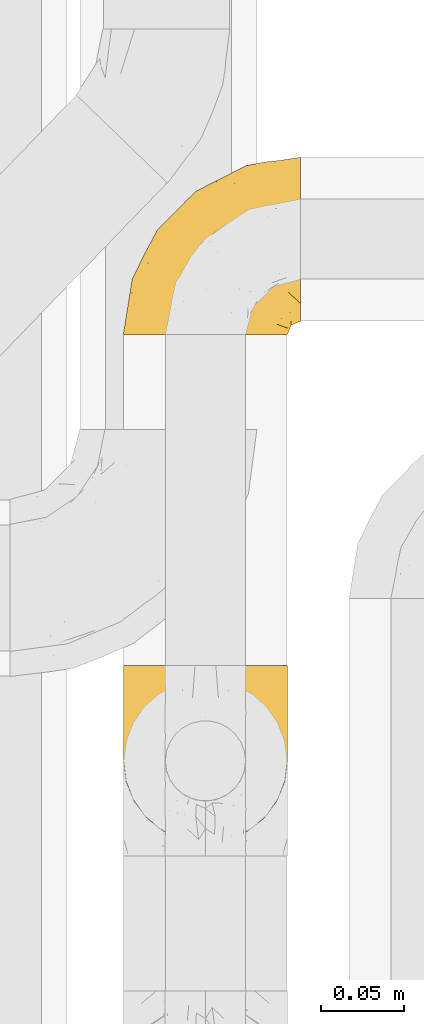
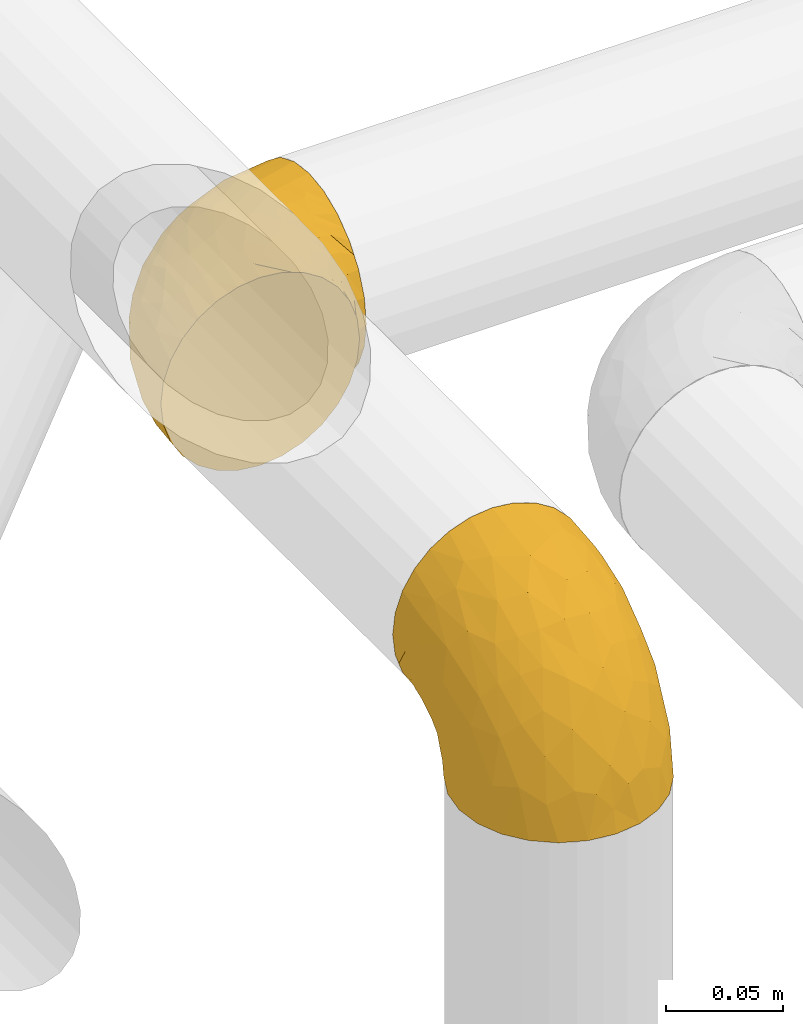
# One storey, part 395 of 827: 2 coverings.
"""IFC2X3 building model written with IfcOpenShell, lengths in millimetres."""

from ifc_helpers import new_model, entity, si_unit, converted_unit, derived_unit, direction, frame, origin, place, context, subcontext, project, spatial, faceted_brep, element, save


model = new_model("IFC2X3")

# Units and contexts
model_context = context("Model", 3, precision=0.01, world=origin(), true_north=direction((6.12303176911189e-17, 1.0)))
body_context = subcontext(model_context, "Body", "Model", "MODEL_VIEW")
ifc_project = project(units=[si_unit("LENGTHUNIT", "METRE", prefix="MILLI"), si_unit("AREAUNIT", "SQUARE_METRE"), si_unit("VOLUMEUNIT", "CUBIC_METRE"), converted_unit("PLANEANGLEUNIT", "DEGREE", entity("IfcRatioMeasure", 0.0174532925199433), si_unit("PLANEANGLEUNIT", "RADIAN"), dimensions=[0, 0, 0, 0, 0, 0, 0]), si_unit("MASSUNIT", "GRAM", prefix="KILO"), derived_unit("MASSDENSITYUNIT", [(si_unit("MASSUNIT", "GRAM", prefix="KILO"), 1), (si_unit("LENGTHUNIT", "METRE"), -3)]), derived_unit("MOMENTOFINERTIAUNIT", [(si_unit("LENGTHUNIT", "METRE"), 4)]), si_unit("TIMEUNIT", "SECOND"), si_unit("FREQUENCYUNIT", "HERTZ"), si_unit("THERMODYNAMICTEMPERATUREUNIT", "DEGREE_CELSIUS"), derived_unit("THERMALTRANSMITTANCEUNIT", [(si_unit("MASSUNIT", "GRAM", prefix="KILO"), 1), (si_unit("THERMODYNAMICTEMPERATUREUNIT", "KELVIN"), -1), (si_unit("TIMEUNIT", "SECOND"), -3)]), derived_unit("VOLUMETRICFLOWRATEUNIT", [(si_unit("LENGTHUNIT", "METRE"), 3), (si_unit("TIMEUNIT", "SECOND"), -1)]), derived_unit("MASSFLOWRATEUNIT", [(si_unit("MASSUNIT", "GRAM", prefix="KILO"), 1), (si_unit("TIMEUNIT", "SECOND"), -1)]), derived_unit("ROTATIONALFREQUENCYUNIT", [(si_unit("TIMEUNIT", "SECOND"), -1)]), si_unit("ELECTRICCURRENTUNIT", "AMPERE"), si_unit("ELECTRICVOLTAGEUNIT", "VOLT"), si_unit("POWERUNIT", "WATT"), si_unit("FORCEUNIT", "NEWTON", prefix="KILO"), si_unit("ILLUMINANCEUNIT", "LUX"), si_unit("LUMINOUSFLUXUNIT", "LUMEN"), si_unit("LUMINOUSINTENSITYUNIT", "CANDELA"), derived_unit("USERDEFINED", [(si_unit("MASSUNIT", "GRAM", prefix="KILO"), -1), (si_unit("LENGTHUNIT", "METRE"), -2), (si_unit("TIMEUNIT", "SECOND"), 3), (si_unit("LUMINOUSFLUXUNIT", "LUMEN"), 1)]), derived_unit("LINEARVELOCITYUNIT", [(si_unit("LENGTHUNIT", "METRE"), 1), (si_unit("TIMEUNIT", "SECOND"), -1)]), si_unit("PRESSUREUNIT", "PASCAL"), derived_unit("USERDEFINED", [(si_unit("LENGTHUNIT", "METRE"), -2), (si_unit("MASSUNIT", "GRAM", prefix="KILO"), 1), (si_unit("TIMEUNIT", "SECOND"), -2)]), derived_unit("LINEARFORCEUNIT", [(si_unit("MASSUNIT", "GRAM", prefix="KILO"), 1), (si_unit("LENGTHUNIT", "METRE"), 1), (si_unit("TIMEUNIT", "SECOND"), -2), (si_unit("LENGTHUNIT", "METRE"), -1)]), derived_unit("PLANARFORCEUNIT", [(si_unit("MASSUNIT", "GRAM", prefix="KILO"), 1), (si_unit("LENGTHUNIT", "METRE"), 1), (si_unit("TIMEUNIT", "SECOND"), -2), (si_unit("LENGTHUNIT", "METRE"), -2)])], contexts=[model_context])

# Site, building, storey
site_placement = place(None, origin())
site = spatial("IfcSite", under=ifc_project, at=site_placement, CompositionType="ELEMENT")
building_placement = place(site_placement, origin())
building = spatial("IfcBuilding", under=site, at=building_placement, CompositionType="ELEMENT")
storey_placement = place(building_placement, frame((0.0, 0.0, 28200.0)))
storey = spatial("IfcBuildingStorey", under=building, at=storey_placement, Name="08", CompositionType="ELEMENT", Elevation=28200.0)

# Coverings
covering_1_placement = place(storey_placement, frame((46642.04, 14383.78, 2941.4)))
element("IfcCovering", 1, at=covering_1_placement, inside=storey, Name=":ADSK_", ObjectType=":ADSK_", PredefinedType="INSULATION", context=body_context, shape_type="Brep", body=[
    faceted_brep([(1.6, 107.75, 58.6), (2.83, 107.75, 69.54), (6.47, 107.75, 79.93), (12.32, 107.75, 89.25), (20.11, 107.75, 97.03), (29.43, 107.75, 102.88), (39.81, 107.75, 106.51), (50.75, 107.75, 107.75), (61.69, 107.75, 106.51), (72.08, 107.75, 102.87), (81.4, 107.75, 97.02), (89.18, 107.75, 89.23), (95.03, 107.75, 79.91), (98.66, 107.75, 69.53), (99.9, 107.75, 58.6), (99.25, 107.75, 52.89), (98.66, 107.75, 47.65), (96.84, 107.75, 42.46), (95.02, 107.75, 37.26), (89.17, 107.75, 27.94), (81.38, 107.75, 20.16), (72.06, 107.75, 14.31), (61.68, 107.75, 10.68), (50.75, 107.75, 9.45), (39.8, 107.75, 10.68), (29.41, 107.75, 14.32), (20.09, 107.75, 20.17), (12.31, 107.75, 27.96), (6.46, 107.75, 37.28), (4.64, 107.75, 42.47), (2.83, 107.75, 47.66), (2.24, 107.75, 52.89), (1.92, 107.75, 55.75), (63.47, 98.22, 1.6), (75.32, 93.31, 1.6), (80.41, 89.4, 1.6), (85.5, 85.5, 1.6), (89.4, 80.41, 1.6), (93.31, 75.32, 1.6), (95.77, 69.39, 1.6), (98.22, 63.47, 1.6), (99.14, 56.48, 1.6), (99.52, 53.61, 1.6), (99.9, 50.75, 1.6), (98.22, 38.02, 1.6), (93.31, 26.17, 1.6), (85.5, 15.99, 1.6), (75.32, 8.18, 1.6), (63.47, 3.27, 1.6), (50.75, 1.6, 1.6), (38.02, 3.27, 1.6), (26.17, 8.18, 1.6), (15.99, 15.99, 1.6), (8.18, 26.17, 1.6), (3.27, 38.02, 1.6), (1.6, 50.75, 1.6), (2.35, 56.48, 1.6), (3.27, 63.47, 1.6), (5.73, 69.39, 1.6), (8.18, 75.32, 1.6), (12.09, 80.41, 1.6), (15.99, 85.5, 1.6), (21.08, 89.4, 1.6), (26.17, 93.31, 1.6), (38.02, 98.22, 1.6), (50.75, 99.9, 1.6), (42.18, 27.53, 69.96), (28.42, 25.32, 59.59), (37.78, 16.29, 51.96), (50.75, 6.79, 34.4), (42.85, 4.51, 23.37), (50.75, 3.51, 13.68), (24.75, 17.47, 41.52), (33.81, 7.6, 26.26), (22.57, 12.27, 20.18), (7.18, 70.89, 72.33), (2.73, 87.17, 65.88), (3.09, 67.3, 57.55), (6.92, 31.65, 23.76), (11.58, 33.58, 46.5), (5.17, 47.23, 46.57), (2.71, 43.26, 21.17), (1.6, 55.08, 23.41), (1.6, 53.99, 17.92), (1.6, 52.9, 12.43), (1.6, 52.36, 9.72), (1.6, 51.82, 7.01), (14.18, 21.5, 26.77), (5.88, 89.94, 76.59), (41.06, 60.45, 95.55), (36.25, 83.0, 102.57), (28.62, 64.79, 92.89), (1.6, 85.93, 54.26), (1.6, 81.31, 51.17), (1.6, 76.69, 48.08), (1.6, 72.06, 44.99), (1.6, 67.44, 41.9), (10.85, 88.74, 85.16), (38.35, 45.98, 85.97), (9.6, 47.13, 59.58), (26.24, 89.4, 99.5), (50.75, 95.66, 105.83), (19.31, 28.5, 53.59), (16.41, 42.81, 67.0), (24.56, 38.28, 71.56), (50.75, 45.35, 87.47), (50.75, 33.61, 75.73), (18.47, 82.57, 92.24), (1.6, 105.04, 58.06), (1.6, 102.33, 57.52), (1.6, 96.91, 56.44), (1.6, 91.42, 55.35), (14.36, 65.92, 81.33), (20.64, 53.11, 80.35), (2.32, 54.37, 39.44), (50.75, 74.94, 102.55), (1.6, 64.35, 37.28), (1.6, 61.26, 32.65), (1.6, 58.17, 28.03), (50.75, 21.87, 63.99), (33.88, 34.79, 74.55), (29.24, 48.48, 83.62), (50.75, 60.15, 95.01), (50.75, 14.33, 49.19), (2.8, 99.07, 46.96), (2.48, 60.55, 8.77), (2.7, 64.18, 18.28), (3.2, 64.36, 11.68), (32.98, 103.17, 11.79), (24.67, 101.69, 15.69), (2.95, 87.75, 42.49), (2.19, 89.38, 47.41), (17.92, 88.34, 7.94), (12.02, 82.14, 9.27), (25.73, 94.51, 7.98), (16.63, 89.64, 13.4), (25.6, 98.41, 13.04), (36.72, 99.71, 7.36), (10.66, 89.37, 23.46), (6.87, 88.21, 30.46), (11.12, 95.2, 26.54), (10.31, 79.14, 6.76), (12.84, 101.22, 26.46), (17.38, 99.41, 20.77), (9.74, 84.72, 20.68), (4.63, 97.47, 40.26), (50.75, 102.19, 7.15), (42.52, 104.02, 9.28), (3.12, 82.66, 38.78), (17.58, 95.42, 18.27), (3.97, 78.67, 31.78), (5.94, 72.69, 12.75), (2.73, 66.46, 22.96), (6.23, 75.3, 17.55), (3.45, 72.74, 27.63), (10.84, 82.93, 15.23), (7.98, 99.27, 33.25), (7.33, 93.51, 32.43), (2.39, 67.35, 27.9), (75.76, 94.51, 7.97), (90.65, 82.94, 15.22), (83.57, 88.33, 7.93), (84.85, 89.64, 13.38), (71.05, 103.62, 13.12), (98.54, 87.74, 42.49), (99.3, 89.38, 47.4), (99.9, 81.31, 51.17), (96.86, 97.47, 40.24), (84.1, 99.41, 20.76), (99.9, 52.9, 12.43), (99.9, 51.82, 7.01), (99.9, 51.28, 4.31), (88.63, 101.21, 26.44), (90.36, 95.19, 26.52), (98.29, 64.36, 11.68), (95.55, 72.69, 12.75), (91.18, 79.14, 6.76), (93.49, 99.28, 33.21), (94.15, 93.51, 32.41), (99.01, 60.55, 8.77), (98.76, 66.46, 22.96), (98.85, 63.96, 18.48), (99.9, 96.91, 56.44), (98.69, 99.06, 46.95), (64.78, 99.7, 7.36), (99.9, 53.99, 17.92), (99.9, 55.08, 23.41), (62.91, 103.3, 9.85), (99.9, 102.33, 57.52), (99.9, 99.62, 56.98), (99.9, 76.69, 48.08), (98.37, 82.66, 38.78), (83.9, 95.42, 18.25), (99.9, 72.06, 44.99), (97.51, 78.68, 31.74), (94.62, 88.2, 30.45), (98.04, 72.75, 27.63), (91.73, 84.74, 20.65), (99.9, 91.42, 55.35), (99.9, 85.93, 54.26), (75.87, 98.41, 13.03), (90.83, 89.37, 23.44), (99.1, 67.35, 27.9), (99.9, 61.26, 32.65), (95.26, 75.3, 17.55), (89.47, 82.13, 9.27), (99.9, 58.17, 28.03), (99.9, 64.35, 37.28), (99.9, 67.44, 41.9), (99.09, 54.08, 39.74), (58.64, 4.51, 23.37), (87.31, 21.5, 26.77), (89.93, 33.43, 46.18), (82.22, 28.5, 53.54), (76.74, 17.47, 41.53), (73.12, 25.36, 59.61), (95.54, 90.18, 76.79), (98.7, 86.97, 66.11), (98.79, 43.26, 21.17), (63.71, 16.29, 51.96), (67.68, 7.6, 26.26), (78.92, 12.27, 20.18), (94.57, 31.65, 23.76), (72.88, 64.79, 92.88), (65.25, 83.0, 102.57), (60.44, 60.44, 95.54), (76.94, 38.35, 71.63), (67.61, 34.8, 74.55), (94.38, 71.54, 72.51), (63.11, 45.94, 85.95), (59.31, 27.53, 69.96), (83.03, 82.57, 92.23), (90.66, 88.74, 85.15), (80.8, 53.19, 80.45), (72.22, 48.49, 83.65), (98.39, 67.28, 57.57), (92.31, 52.32, 63.68), (75.27, 89.4, 99.49), (87.15, 65.75, 81.23), (96.03, 46.73, 47.07), (85.1, 42.82, 66.99)], [[[0, 1, 2, 3, 4, 5, 6, 7, 8, 9, 10, 11, 12, 13, 14, 15, 16, 17, 18, 19, 20, 21, 22, 23, 24, 25, 26, 27, 28, 29, 30, 31, 32]], [[33, 34, 35, 36, 37, 38, 39, 40, 41, 42, 43, 44, 45, 46, 47, 48, 49, 50, 51, 52, 53, 54, 55, 56, 57, 58, 59, 60, 61, 62, 63, 64, 65]], [[66, 67, 68]], [[69, 70, 71]], [[68, 72, 73]], [[73, 72, 74]], [[75, 76, 77]], [[78, 79, 80]], [[51, 50, 73]], [[81, 82, 83, 84, 85, 86, 55]], [[52, 87, 53]], [[74, 52, 51]], [[2, 1, 88]], [[89, 90, 91]], [[77, 92, 93, 94, 95, 96]], [[55, 54, 81]], [[78, 53, 87]], [[5, 90, 6]], [[88, 76, 75]], [[97, 3, 2]], [[89, 91, 98]], [[99, 80, 79]], [[90, 5, 100]], [[74, 87, 52]], [[100, 5, 4]], [[90, 101, 6]], [[79, 102, 103]], [[102, 67, 104]], [[105, 98, 106]], [[107, 4, 3]], [[76, 0, 108, 109, 110, 111, 92]], [[107, 112, 113]], [[114, 77, 96]], [[89, 115, 90]], [[114, 96, 116, 117, 118, 82]], [[75, 97, 88]], [[119, 66, 68]], [[50, 71, 70]], [[100, 91, 90]], [[99, 77, 80]], [[102, 104, 103]], [[97, 107, 3]], [[80, 81, 78]], [[107, 97, 112]], [[68, 73, 70]], [[66, 98, 120]], [[78, 81, 54]], [[114, 81, 80]], [[53, 78, 54]], [[78, 87, 79]], [[102, 87, 72]], [[79, 103, 99]], [[4, 107, 100]], [[91, 100, 107]], [[88, 97, 2]], [[112, 97, 75]], [[99, 112, 75]], [[103, 104, 113]], [[91, 121, 98]], [[89, 105, 122, 115]], [[101, 90, 115]], [[101, 7, 6]], [[88, 1, 76]], [[0, 76, 1]], [[92, 77, 76]], [[73, 74, 51]], [[87, 74, 72]], [[81, 114, 82]], [[77, 114, 80]], [[87, 102, 79]], [[67, 102, 72]], [[68, 67, 72]], [[67, 120, 104]], [[120, 121, 104]], [[104, 121, 113]], [[121, 120, 98]], [[91, 107, 113]], [[91, 113, 121]], [[103, 113, 112]], [[106, 98, 66]], [[105, 89, 98]], [[106, 66, 119]], [[67, 66, 120]], [[68, 69, 123, 119]], [[50, 49, 71]], [[50, 70, 73]], [[112, 99, 103]], [[77, 99, 75]], [[69, 68, 70]], [[29, 124, 110]], [[84, 83, 125]], [[126, 82, 118]], [[59, 58, 127]], [[25, 128, 129]], [[130, 93, 131]], [[132, 62, 133]], [[134, 135, 136]], [[137, 65, 64]], [[64, 134, 137]], [[138, 139, 140]], [[111, 110, 124, 92]], [[134, 136, 137]], [[134, 64, 63]], [[133, 61, 141]], [[125, 58, 57]], [[142, 143, 140]], [[142, 26, 143]], [[127, 83, 82]], [[28, 124, 29]], [[108, 0, 32, 31, 30, 110, 109]], [[30, 29, 110]], [[135, 144, 138]], [[28, 145, 124]], [[57, 56, 55, 86, 85, 84]], [[146, 147, 23]], [[24, 23, 147]], [[25, 143, 26]], [[95, 94, 148]], [[24, 128, 25]], [[149, 138, 143]], [[124, 145, 131]], [[127, 58, 125]], [[150, 148, 139]], [[127, 126, 151]], [[151, 59, 127]], [[152, 151, 126]], [[153, 154, 155]], [[153, 133, 141]], [[145, 28, 27]], [[142, 156, 27]], [[157, 148, 130]], [[61, 133, 62]], [[134, 132, 135]], [[147, 128, 24]], [[65, 137, 146]], [[146, 137, 147]], [[128, 137, 136]], [[137, 128, 147]], [[128, 136, 129]], [[149, 129, 136]], [[25, 129, 143]], [[158, 152, 117]], [[152, 118, 117]], [[153, 151, 152]], [[158, 116, 154]], [[144, 150, 138]], [[153, 152, 158]], [[133, 153, 155]], [[133, 155, 132]], [[141, 61, 60]], [[135, 132, 155]], [[134, 63, 132]], [[144, 135, 155]], [[135, 138, 149]], [[155, 154, 144]], [[150, 154, 96]], [[154, 150, 144]], [[148, 94, 130]], [[82, 126, 127]], [[118, 152, 126]], [[150, 96, 95]], [[139, 148, 157]], [[150, 95, 148]], [[93, 92, 131]], [[130, 145, 156]], [[130, 94, 93]], [[84, 125, 57]], [[127, 125, 83]], [[140, 139, 157]], [[150, 139, 138]], [[140, 157, 142]], [[138, 140, 143]], [[156, 142, 157]], [[27, 26, 142]], [[130, 156, 157]], [[145, 27, 156]], [[132, 63, 62]], [[124, 131, 92]], [[130, 131, 145]], [[129, 149, 143]], [[135, 149, 136]], [[60, 151, 141]], [[59, 151, 60]], [[141, 151, 153]], [[116, 96, 154]], [[153, 158, 154]], [[158, 117, 116]], [[34, 33, 159]], [[160, 161, 162]], [[22, 21, 163]], [[164, 165, 166]], [[19, 18, 167]], [[168, 21, 20]], [[42, 41, 40, 169, 170, 171, 43]], [[172, 173, 168]], [[174, 38, 175]], [[37, 36, 176]], [[177, 164, 178]], [[40, 179, 169]], [[180, 181, 175]], [[17, 182, 183]], [[65, 146, 184]], [[185, 174, 186]], [[23, 22, 187]], [[174, 39, 38]], [[15, 14, 188, 189, 182, 16]], [[179, 40, 39]], [[190, 191, 164]], [[192, 163, 168]], [[33, 184, 159]], [[178, 173, 172]], [[193, 194, 191]], [[18, 183, 167]], [[173, 178, 195]], [[196, 197, 194]], [[198, 199, 183, 182]], [[182, 17, 16]], [[18, 17, 183]], [[200, 159, 184]], [[192, 168, 201]], [[187, 163, 200]], [[202, 203, 180]], [[185, 179, 174]], [[160, 204, 205]], [[206, 181, 180]], [[206, 180, 203]], [[199, 165, 183]], [[165, 164, 167]], [[172, 177, 178]], [[200, 192, 162]], [[205, 161, 160]], [[65, 184, 33]], [[163, 187, 22]], [[175, 204, 180]], [[174, 181, 186]], [[204, 196, 202]], [[197, 160, 162]], [[196, 207, 202]], [[37, 176, 175]], [[196, 204, 160]], [[176, 204, 175]], [[205, 35, 161]], [[34, 159, 161]], [[162, 161, 159]], [[200, 162, 159]], [[197, 162, 201]], [[194, 197, 201]], [[196, 160, 197]], [[191, 195, 178]], [[208, 196, 194]], [[186, 181, 206]], [[175, 181, 174]], [[191, 190, 193]], [[193, 208, 194]], [[195, 194, 201]], [[178, 164, 191]], [[168, 163, 21]], [[166, 165, 199]], [[166, 190, 164]], [[187, 200, 184]], [[184, 146, 187]], [[23, 187, 146]], [[174, 179, 39]], [[169, 179, 185]], [[194, 195, 191]], [[173, 201, 168]], [[201, 173, 195]], [[172, 168, 20]], [[20, 19, 172]], [[177, 172, 19]], [[19, 167, 177]], [[164, 177, 167]], [[35, 205, 36]], [[35, 34, 161]], [[183, 165, 167]], [[162, 192, 201]], [[163, 192, 200]], [[175, 38, 37]], [[36, 205, 176]], [[204, 176, 205]], [[204, 202, 180]], [[207, 196, 208]], [[207, 203, 202]], [[209, 186, 206, 203, 207, 208]], [[48, 210, 71]], [[211, 212, 213]], [[214, 213, 215]], [[216, 217, 13]], [[218, 43, 171, 170, 169, 185, 186]], [[219, 220, 214]], [[47, 46, 221]], [[210, 48, 220]], [[211, 222, 212]], [[222, 45, 44]], [[221, 220, 47]], [[47, 220, 48]], [[221, 211, 214]], [[223, 224, 225]], [[211, 46, 45]], [[226, 227, 215]], [[43, 218, 44]], [[217, 216, 228]], [[227, 229, 230]], [[14, 13, 217]], [[224, 9, 8]], [[10, 231, 11]], [[11, 232, 12]], [[233, 223, 234]], [[235, 208, 193, 190, 166, 199]], [[236, 235, 228]], [[222, 44, 218]], [[106, 230, 229]], [[224, 237, 9]], [[232, 238, 228]], [[9, 237, 10]], [[115, 224, 101]], [[239, 235, 236]], [[232, 11, 231]], [[223, 231, 237]], [[224, 8, 101]], [[223, 229, 234]], [[225, 115, 122, 105]], [[216, 12, 232]], [[209, 235, 239]], [[210, 219, 69]], [[219, 214, 215]], [[230, 119, 219]], [[209, 218, 186]], [[239, 212, 222]], [[239, 222, 218]], [[45, 222, 211]], [[236, 212, 239]], [[213, 212, 240]], [[223, 237, 224]], [[231, 10, 237]], [[238, 232, 231]], [[216, 232, 228]], [[233, 231, 223]], [[236, 238, 240]], [[115, 225, 224]], [[234, 229, 227]], [[8, 7, 101]], [[235, 209, 208]], [[218, 209, 239]], [[217, 228, 235]], [[13, 12, 216]], [[235, 199, 217]], [[217, 199, 198, 182, 189, 188, 14]], [[211, 221, 46]], [[220, 221, 214]], [[71, 210, 69]], [[71, 49, 48]], [[219, 210, 220]], [[226, 215, 213]], [[211, 213, 214]], [[226, 213, 240]], [[215, 227, 230]], [[233, 240, 238]], [[234, 227, 226]], [[233, 234, 226]], [[229, 223, 225]], [[240, 233, 226]], [[233, 238, 231]], [[225, 105, 229]], [[229, 105, 106]], [[106, 119, 230]], [[123, 69, 219, 119]], [[215, 230, 219]], [[238, 236, 228]], [[212, 236, 240]]]),
])
covering_2_placement = place(storey_placement, frame((46642.04, 14688.43, 2949.25)))
element("IfcCovering", 2, at=covering_2_placement, inside=storey, Name=":ADSK_", ObjectType=":ADSK_", PredefinedType="INSULATION", context=body_context, shape_type="Brep", body=[
    faceted_brep([(50.75, 1.6, 99.9), (39.8, 1.6, 98.66), (29.41, 1.6, 95.02), (20.09, 1.6, 89.17), (12.31, 1.6, 81.38), (6.46, 1.6, 72.06), (2.83, 1.6, 61.68), (1.6, 1.6, 50.75), (2.83, 1.6, 39.8), (6.47, 1.6, 29.41), (12.32, 1.6, 20.09), (20.11, 1.6, 12.31), (29.43, 1.6, 6.46), (39.81, 1.6, 2.83), (50.75, 1.6, 1.6), (56.45, 1.6, 2.24), (61.69, 1.6, 2.83), (66.88, 1.6, 4.65), (72.08, 1.6, 6.47), (81.4, 1.6, 12.32), (89.18, 1.6, 20.11), (95.03, 1.6, 29.43), (98.66, 1.6, 39.81), (99.9, 1.6, 50.75), (98.66, 1.6, 61.69), (95.02, 1.6, 72.08), (89.17, 1.6, 81.4), (81.38, 1.6, 89.18), (72.06, 1.6, 95.03), (66.87, 1.6, 96.85), (61.68, 1.6, 98.66), (56.45, 1.6, 99.25), (53.6, 1.6, 99.57), (107.75, 11.12, 38.02), (107.75, 16.03, 26.17), (107.75, 19.94, 21.08), (107.75, 23.84, 15.99), (107.75, 28.93, 12.09), (107.75, 34.02, 8.18), (107.75, 39.95, 5.73), (107.75, 45.87, 3.27), (107.75, 52.86, 2.35), (107.75, 55.73, 1.97), (107.75, 58.6, 1.6), (107.75, 71.32, 3.27), (107.75, 83.17, 8.18), (107.75, 93.35, 15.99), (107.75, 101.16, 26.17), (107.75, 106.07, 38.02), (107.75, 107.75, 50.75), (107.75, 106.07, 63.47), (107.75, 101.16, 75.32), (107.75, 93.35, 85.5), (107.75, 83.17, 93.31), (107.75, 71.32, 98.22), (107.75, 58.6, 99.9), (107.75, 52.86, 99.14), (107.75, 45.87, 98.22), (107.75, 39.95, 95.77), (107.75, 34.02, 93.31), (107.75, 28.93, 89.4), (107.75, 23.84, 85.5), (107.75, 19.94, 80.41), (107.75, 16.03, 75.32), (107.75, 11.12, 63.47), (107.75, 9.45, 50.75), (39.38, 81.82, 59.31), (49.75, 84.02, 73.08), (57.38, 93.05, 63.72), (74.94, 102.55, 50.75), (85.97, 104.83, 58.64), (95.66, 105.83, 50.75), (67.82, 91.87, 76.74), (83.09, 101.74, 67.68), (89.16, 97.07, 78.92), (37.01, 38.45, 94.31), (43.46, 22.17, 98.76), (51.79, 42.04, 98.4), (85.58, 77.69, 94.57), (62.84, 75.76, 89.91), (62.77, 62.11, 96.32), (88.17, 66.08, 98.79), (85.93, 54.26, 99.9), (91.42, 55.35, 99.9), (96.91, 56.44, 99.9), (99.62, 56.98, 99.9), (102.33, 57.52, 99.9), (82.57, 87.84, 87.31), (32.75, 19.41, 95.61), (13.79, 48.89, 60.43), (6.77, 26.34, 65.24), (16.46, 44.55, 72.87), (55.08, 23.41, 99.9), (58.17, 28.03, 99.9), (61.26, 32.65, 99.9), (64.35, 37.28, 99.9), (67.44, 41.9, 99.9), (24.18, 20.6, 90.65), (23.37, 63.36, 63.14), (49.76, 62.21, 91.89), (9.84, 19.94, 75.25), (3.51, 13.68, 50.75), (55.75, 80.85, 82.18), (42.34, 66.53, 85.08), (37.78, 71.06, 76.93), (21.87, 63.99, 50.75), (33.61, 75.73, 50.75), (17.1, 26.77, 83.02), (51.28, 4.31, 99.9), (51.82, 7.01, 99.9), (52.9, 12.43, 99.9), (53.99, 17.92, 99.9), (28.01, 43.43, 87.13), (28.99, 56.23, 80.85), (69.9, 54.97, 99.17), (6.79, 34.4, 50.75), (72.06, 44.99, 99.9), (76.69, 48.08, 99.9), (81.31, 51.17, 99.9), (45.35, 87.47, 50.75), (34.79, 74.55, 67.61), (25.72, 60.86, 72.25), (14.33, 49.19, 50.75), (60.15, 95.01, 50.75), (62.38, 10.27, 98.69), (100.57, 48.79, 99.01), (91.06, 45.16, 98.79), (97.66, 44.99, 98.29), (97.55, 6.17, 68.51), (93.65, 7.65, 76.82), (66.85, 21.59, 98.54), (61.93, 19.96, 99.3), (101.4, 21.0, 83.57), (100.07, 27.2, 89.47), (101.36, 14.83, 75.76), (95.94, 19.7, 84.86), (96.3, 10.93, 75.89), (101.98, 9.63, 64.77), (85.88, 19.97, 90.83), (78.88, 21.13, 94.62), (82.8, 14.14, 90.37), (102.58, 30.2, 91.18), (82.88, 8.12, 88.65), (88.57, 9.93, 84.11), (88.67, 24.62, 91.75), (69.08, 11.87, 96.86), (102.19, 7.15, 50.75), (100.06, 5.32, 58.97), (70.56, 26.68, 98.37), (91.07, 13.92, 83.91), (77.56, 30.67, 97.52), (96.59, 36.65, 95.55), (86.38, 42.89, 98.76), (91.79, 34.04, 95.26), (81.71, 36.6, 98.04), (94.11, 26.41, 90.65), (76.09, 10.07, 93.51), (76.91, 15.83, 94.16), (81.44, 41.99, 99.1), (101.37, 14.83, 25.73), (94.12, 26.4, 10.84), (101.41, 21.01, 17.92), (95.96, 19.71, 16.64), (96.22, 5.72, 30.44), (66.85, 21.6, 2.95), (61.94, 19.96, 2.19), (58.17, 28.03, 1.6), (69.1, 11.87, 4.63), (88.58, 9.93, 17.39), (96.91, 56.44, 1.6), (102.33, 57.52, 1.6), (105.04, 58.06, 1.6), (82.9, 8.13, 12.86), (82.82, 14.15, 11.13), (97.66, 44.99, 3.2), (96.59, 36.65, 5.94), (100.07, 27.21, 12.02), (91.79, 34.04, 6.23), (102.58, 30.2, 10.31), (76.13, 10.06, 8.0), (76.93, 15.83, 7.34), (100.57, 48.79, 2.48), (86.38, 42.89, 2.73), (90.86, 45.38, 2.64), (52.9, 12.43, 1.6), (62.39, 10.28, 2.8), (101.98, 9.64, 36.71), (91.42, 55.35, 1.6), (85.93, 54.26, 1.6), (99.49, 6.05, 38.59), (51.82, 7.01, 1.6), (52.36, 9.72, 1.6), (61.26, 32.65, 1.6), (70.56, 26.68, 3.12), (91.09, 13.92, 17.59), (64.35, 37.28, 1.6), (77.6, 30.66, 3.98), (78.89, 21.14, 6.87), (81.71, 36.59, 3.45), (88.69, 24.6, 9.76), (53.99, 17.92, 1.6), (55.08, 23.41, 1.6), (96.31, 10.93, 25.62), (85.9, 19.97, 10.67), (81.45, 41.99, 2.39), (76.69, 48.08, 1.6), (81.31, 51.17, 1.6), (72.06, 44.99, 1.6), (67.44, 41.9, 1.6), (69.6, 55.26, 2.4), (85.97, 104.83, 42.85), (82.57, 87.84, 14.18), (63.16, 75.91, 11.56), (55.81, 80.84, 19.27), (67.81, 91.87, 24.75), (49.73, 83.98, 28.37), (32.55, 19.16, 5.95), (43.23, 22.37, 2.79), (88.17, 66.08, 2.71), (57.38, 93.05, 37.78), (83.08, 101.74, 33.81), (89.16, 97.07, 22.57), (85.58, 77.69, 6.92), (16.46, 44.55, 28.61), (6.77, 26.34, 36.24), (13.8, 48.9, 41.05), (37.71, 70.99, 24.55), (34.8, 74.55, 33.88), (36.83, 37.8, 7.11), (39.38, 81.82, 42.18), (17.12, 26.77, 18.46), (24.19, 20.6, 10.84), (28.89, 56.15, 20.69), (25.69, 60.85, 29.27), (51.77, 42.06, 3.1), (45.66, 57.03, 9.18), (23.39, 63.4, 38.38), (9.85, 19.94, 26.23), (28.11, 43.59, 14.34), (62.27, 62.61, 5.46), (42.35, 66.52, 16.39)], [[[0, 1, 2, 3, 4, 5, 6, 7, 8, 9, 10, 11, 12, 13, 14, 15, 16, 17, 18, 19, 20, 21, 22, 23, 24, 25, 26, 27, 28, 29, 30, 31, 32]], [[33, 34, 35, 36, 37, 38, 39, 40, 41, 42, 43, 44, 45, 46, 47, 48, 49, 50, 51, 52, 53, 54, 55, 56, 57, 58, 59, 60, 61, 62, 63, 64, 65]], [[66, 67, 68]], [[69, 70, 71]], [[68, 72, 73]], [[73, 72, 74]], [[75, 76, 77]], [[78, 79, 80]], [[51, 50, 73]], [[81, 82, 83, 84, 85, 86, 55]], [[52, 87, 53]], [[74, 52, 51]], [[2, 1, 88]], [[89, 90, 91]], [[77, 92, 93, 94, 95, 96]], [[55, 54, 81]], [[78, 53, 87]], [[5, 90, 6]], [[88, 76, 75]], [[97, 3, 2]], [[89, 91, 98]], [[99, 80, 79]], [[90, 5, 100]], [[74, 87, 52]], [[100, 5, 4]], [[90, 101, 6]], [[79, 102, 103]], [[102, 67, 104]], [[105, 98, 106]], [[107, 4, 3]], [[76, 0, 108, 109, 110, 111, 92]], [[107, 112, 113]], [[114, 77, 96]], [[89, 115, 90]], [[114, 96, 116, 117, 118, 82]], [[75, 97, 88]], [[119, 66, 68]], [[50, 71, 70]], [[100, 91, 90]], [[99, 77, 80]], [[102, 104, 103]], [[97, 107, 3]], [[80, 81, 78]], [[107, 97, 112]], [[68, 73, 70]], [[66, 98, 120]], [[78, 81, 54]], [[114, 81, 80]], [[53, 78, 54]], [[78, 87, 79]], [[102, 87, 72]], [[79, 103, 99]], [[4, 107, 100]], [[91, 100, 107]], [[88, 97, 2]], [[112, 97, 75]], [[99, 112, 75]], [[103, 104, 113]], [[91, 121, 98]], [[89, 105, 122, 115]], [[101, 90, 115]], [[101, 7, 6]], [[88, 1, 76]], [[0, 76, 1]], [[92, 77, 76]], [[73, 74, 51]], [[87, 74, 72]], [[81, 114, 82]], [[77, 114, 80]], [[87, 102, 79]], [[67, 102, 72]], [[68, 67, 72]], [[67, 120, 104]], [[120, 121, 104]], [[104, 121, 113]], [[121, 120, 98]], [[91, 107, 113]], [[91, 113, 121]], [[103, 113, 112]], [[106, 98, 66]], [[105, 89, 98]], [[106, 66, 119]], [[67, 66, 120]], [[68, 69, 123, 119]], [[50, 49, 71]], [[50, 70, 73]], [[112, 99, 103]], [[77, 99, 75]], [[69, 68, 70]], [[29, 124, 110]], [[84, 83, 125]], [[126, 82, 118]], [[59, 58, 127]], [[25, 128, 129]], [[130, 93, 131]], [[132, 62, 133]], [[134, 135, 136]], [[137, 65, 64]], [[64, 134, 137]], [[138, 139, 140]], [[111, 110, 124, 92]], [[134, 136, 137]], [[134, 64, 63]], [[141, 61, 60]], [[125, 58, 57]], [[142, 143, 140]], [[142, 26, 143]], [[127, 83, 82]], [[28, 124, 29]], [[108, 0, 32, 31, 30, 110, 109]], [[30, 29, 110]], [[135, 144, 138]], [[28, 145, 124]], [[57, 56, 55, 86, 85, 84]], [[146, 147, 23]], [[24, 23, 147]], [[25, 143, 26]], [[95, 94, 148]], [[24, 128, 25]], [[149, 138, 143]], [[124, 145, 131]], [[127, 58, 125]], [[150, 148, 139]], [[127, 126, 151]], [[151, 59, 127]], [[152, 151, 126]], [[153, 154, 155]], [[153, 133, 141]], [[145, 28, 27]], [[142, 156, 27]], [[157, 148, 130]], [[61, 133, 62]], [[134, 132, 135]], [[147, 128, 24]], [[65, 137, 146]], [[146, 137, 147]], [[128, 137, 136]], [[137, 128, 147]], [[128, 136, 129]], [[149, 129, 136]], [[25, 129, 143]], [[158, 152, 117]], [[152, 118, 117]], [[153, 151, 152]], [[158, 116, 154]], [[144, 150, 138]], [[153, 152, 158]], [[133, 153, 155]], [[133, 155, 132]], [[60, 151, 141]], [[135, 132, 155]], [[134, 63, 132]], [[144, 135, 155]], [[135, 138, 149]], [[155, 154, 144]], [[150, 154, 96]], [[154, 150, 144]], [[148, 94, 130]], [[82, 126, 127]], [[118, 152, 126]], [[150, 96, 95]], [[139, 148, 157]], [[150, 95, 148]], [[93, 92, 131]], [[130, 145, 156]], [[130, 94, 93]], [[84, 125, 57]], [[127, 125, 83]], [[140, 139, 157]], [[150, 139, 138]], [[140, 157, 142]], [[138, 140, 143]], [[156, 142, 157]], [[27, 26, 142]], [[130, 156, 157]], [[145, 27, 156]], [[132, 63, 62]], [[124, 131, 92]], [[130, 131, 145]], [[129, 149, 143]], [[135, 149, 136]], [[141, 133, 61]], [[60, 59, 151]], [[141, 151, 153]], [[116, 96, 154]], [[153, 158, 154]], [[158, 117, 116]], [[34, 33, 159]], [[160, 161, 162]], [[22, 21, 163]], [[164, 165, 166]], [[19, 18, 167]], [[168, 21, 20]], [[42, 41, 40, 169, 170, 171, 43]], [[172, 173, 168]], [[174, 38, 175]], [[176, 177, 178]], [[179, 164, 180]], [[40, 181, 169]], [[182, 183, 175]], [[17, 184, 185]], [[65, 146, 186]], [[187, 174, 188]], [[23, 22, 189]], [[174, 39, 38]], [[15, 14, 190, 191, 184, 16]], [[181, 40, 39]], [[192, 193, 164]], [[194, 163, 168]], [[33, 186, 159]], [[180, 173, 172]], [[195, 196, 193]], [[18, 185, 167]], [[173, 180, 197]], [[198, 199, 196]], [[200, 201, 185, 184]], [[184, 17, 16]], [[18, 17, 185]], [[202, 159, 186]], [[194, 168, 203]], [[189, 163, 202]], [[204, 205, 182]], [[187, 181, 174]], [[160, 177, 176]], [[206, 183, 182]], [[206, 182, 205]], [[201, 165, 185]], [[165, 164, 167]], [[172, 179, 180]], [[202, 194, 162]], [[176, 161, 160]], [[65, 186, 33]], [[163, 189, 22]], [[175, 177, 182]], [[174, 183, 188]], [[177, 198, 204]], [[199, 160, 162]], [[198, 207, 204]], [[175, 38, 37]], [[198, 177, 160]], [[178, 177, 175]], [[176, 35, 161]], [[34, 159, 161]], [[162, 161, 159]], [[202, 162, 159]], [[199, 162, 203]], [[196, 199, 203]], [[198, 160, 199]], [[193, 197, 180]], [[208, 198, 196]], [[188, 183, 206]], [[175, 183, 174]], [[193, 192, 195]], [[195, 208, 196]], [[197, 196, 203]], [[180, 164, 193]], [[168, 163, 21]], [[166, 165, 201]], [[166, 192, 164]], [[189, 202, 186]], [[186, 146, 189]], [[23, 189, 146]], [[174, 181, 39]], [[169, 181, 187]], [[196, 197, 193]], [[173, 203, 168]], [[203, 173, 197]], [[172, 168, 20]], [[20, 19, 172]], [[179, 172, 19]], [[19, 167, 179]], [[164, 179, 167]], [[35, 176, 36]], [[35, 34, 161]], [[185, 165, 167]], [[162, 194, 203]], [[163, 194, 202]], [[176, 178, 36]], [[37, 36, 178]], [[175, 37, 178]], [[177, 204, 182]], [[207, 198, 208]], [[207, 205, 204]], [[209, 188, 206, 205, 207, 208]], [[48, 210, 71]], [[211, 212, 213]], [[214, 213, 215]], [[216, 217, 13]], [[218, 43, 171, 170, 169, 187, 188]], [[219, 220, 214]], [[47, 46, 221]], [[210, 48, 220]], [[211, 222, 212]], [[222, 45, 44]], [[221, 220, 47]], [[47, 220, 48]], [[221, 211, 214]], [[223, 224, 225]], [[211, 46, 45]], [[226, 227, 215]], [[43, 218, 44]], [[217, 216, 228]], [[219, 215, 229]], [[14, 13, 217]], [[224, 9, 8]], [[10, 230, 11]], [[11, 231, 12]], [[232, 223, 233]], [[234, 208, 195, 192, 166, 201]], [[235, 234, 228]], [[222, 44, 218]], [[106, 229, 236]], [[224, 237, 9]], [[231, 238, 228]], [[9, 237, 10]], [[115, 224, 101]], [[239, 234, 235]], [[231, 11, 230]], [[223, 230, 237]], [[224, 8, 101]], [[223, 236, 233]], [[225, 115, 122, 105]], [[216, 12, 231]], [[209, 234, 239]], [[210, 219, 69]], [[219, 214, 215]], [[229, 119, 219]], [[209, 218, 188]], [[239, 212, 222]], [[239, 222, 218]], [[45, 222, 211]], [[235, 212, 239]], [[213, 212, 240]], [[223, 237, 224]], [[230, 10, 237]], [[238, 231, 230]], [[216, 231, 228]], [[232, 230, 223]], [[235, 238, 240]], [[115, 225, 224]], [[233, 236, 227]], [[8, 7, 101]], [[234, 209, 208]], [[218, 209, 239]], [[217, 228, 234]], [[13, 12, 216]], [[234, 201, 217]], [[217, 201, 200, 184, 191, 190, 14]], [[211, 221, 46]], [[220, 221, 214]], [[71, 210, 69]], [[71, 49, 48]], [[219, 210, 220]], [[226, 215, 213]], [[211, 213, 214]], [[226, 213, 240]], [[215, 227, 229]], [[232, 240, 238]], [[233, 227, 226]], [[232, 233, 226]], [[236, 223, 225]], [[240, 232, 226]], [[232, 238, 230]], [[225, 105, 236]], [[236, 105, 106]], [[236, 229, 227]], [[123, 69, 219, 119]], [[106, 119, 229]], [[238, 235, 228]], [[212, 235, 240]]]),
])

save(model, "model.ifc")
